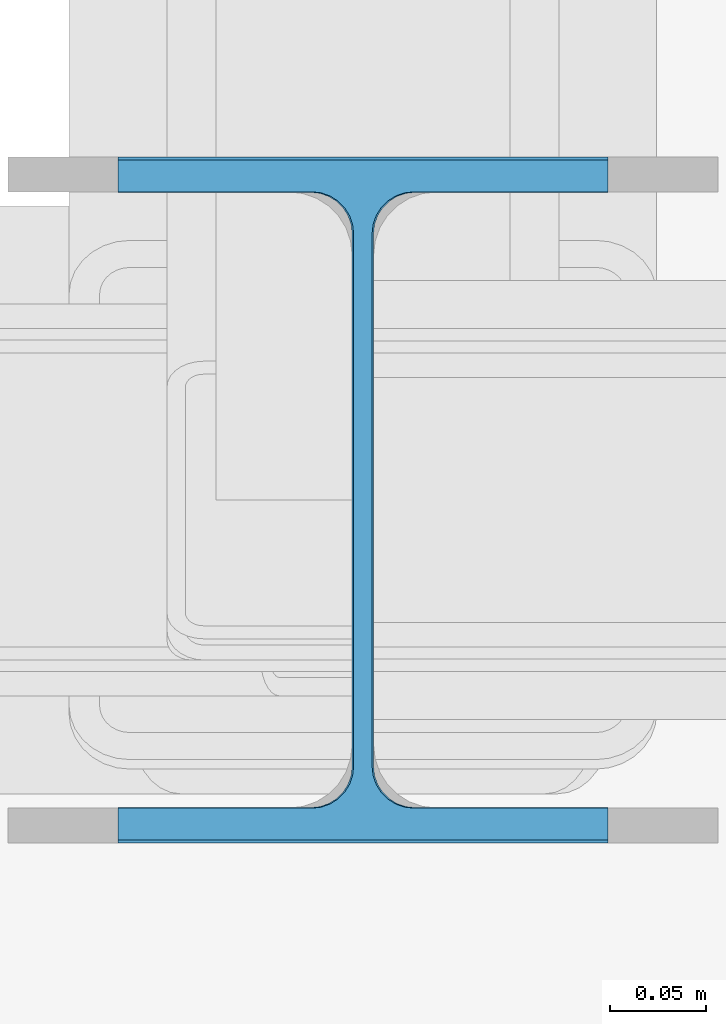
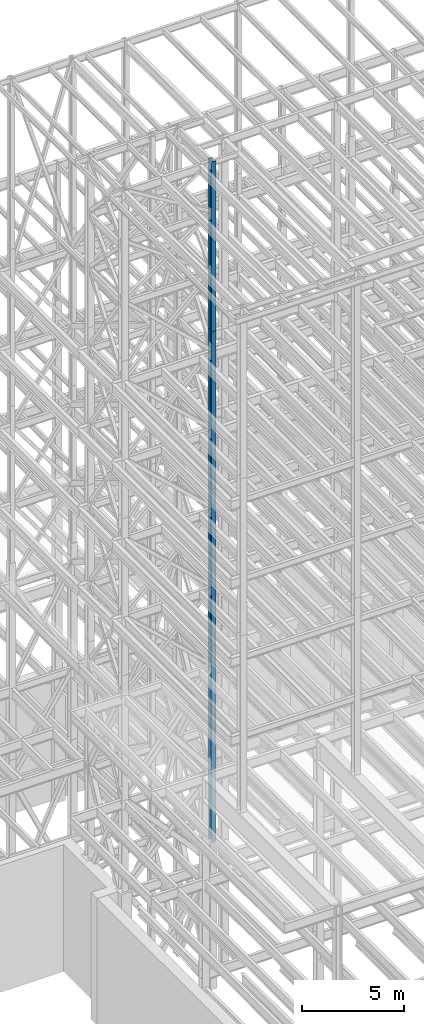
# One storey, part 11 of 150: 4 columns.
"""IFC2X3 building model written with IfcOpenShell, lengths in millimetres."""

from ifc_helpers import new_model, si_unit, frame, origin_with_axes, origin_2d_with_axis, place, context, subcontext, project, spatial, i_section, extrude, material, type_object, element, save


model = new_model("IFC2X3")

# Units and contexts
model_context = context("Model", 3, precision=1e-05, world=origin_with_axes())
body_context = subcontext(model_context, "Body", "Model", "MODEL_VIEW")
ifc_project = project(units=[si_unit("LENGTHUNIT", "METRE", prefix="MILLI"), si_unit("AREAUNIT", "SQUARE_METRE"), si_unit("VOLUMEUNIT", "CUBIC_METRE"), si_unit("MASSUNIT", "GRAM", prefix="KILO"), si_unit("TIMEUNIT", "SECOND"), si_unit("PLANEANGLEUNIT", "RADIAN"), si_unit("SOLIDANGLEUNIT", "STERADIAN"), si_unit("THERMODYNAMICTEMPERATUREUNIT", "DEGREE_CELSIUS"), si_unit("LUMINOUSINTENSITYUNIT", "LUMEN")], contexts=[model_context])

# Site, building, storey
site_placement = place(None, origin_with_axes())
site = spatial("IfcSite", under=ifc_project, at=site_placement, CompositionType="ELEMENT")
building_placement = place(site_placement, origin_with_axes())
building = spatial("IfcBuilding", under=site, at=building_placement, Name="Undefined", CompositionType="ELEMENT")
storey_placement = place(building_placement, origin_with_axes())
storey = spatial("IfcBuildingStorey", under=building, at=storey_placement, Name="Undefined", CompositionType="ELEMENT", Elevation=0.0)

# Columns
ifc_material = material(Name="STEEL/A992")
column_type_1 = type_object("IfcColumnType", Name="W14X61", PredefinedType="NOTDEFINED")
column_1_placement = place(storey_placement, frame((10312.39949708, 21043.9, 55702.2), z_axis=(0.0, 0.0, 1.0), x_axis=(1.0, 0.0, 0.0)))
element("IfcColumn", 1, at=column_1_placement, inside=storey, type_object=column_type_1, material=ifc_material, Name="COLUMN", ObjectType="W14X61", context=body_context, shape_type="SweptSolid", body=[
    extrude(i_section(OverallWidth=254.0, OverallDepth=352.425, WebThickness=9.5249, FlangeThickness=16.383, FilletRadius=21.717, at=origin_2d_with_axis()), frame((0.0, 0.0, 10210.8), z_axis=(0.0, 0.0, -1.0), x_axis=(-1.0, 0.0, 0.0)), (0.0, 0.0, 1.0), 10210.8),
])
for number, where, z_axis, x_axis, name in (
    (2, (10312.39949708, 21043.9, 46253.4), (0.0, 0.0, 1.0), (1.0, 0.0, 0.0), "COLUMN"),
    (3, (10312.39949708, 21043.9, 36804.6), (0.0, 0.0, 1.0), (1.0, 0.0, 0.0), "COLUMN"),
):
    element("IfcColumn", number, at=place(storey_placement, frame(where, z_axis=z_axis, x_axis=x_axis)), inside=storey, type_object=column_type_1, material=ifc_material, Name=name, ObjectType="W14X61", context=body_context, shape_type="SweptSolid", body=[
        extrude(i_section(OverallWidth=254.0, OverallDepth=352.425, WebThickness=9.5249, FlangeThickness=16.383, FilletRadius=21.717, at=origin_2d_with_axis()), frame((0.0, 0.0, 9448.8), z_axis=(0.0, 0.0, -1.0), x_axis=(-1.0, 0.0, 0.0)), (0.0, 0.0, 1.0), 9448.8),
    ])
column_type_2 = type_object("IfcColumnType", Name="W14X68", PredefinedType="NOTDEFINED")
column_2_placement = place(storey_placement, frame((10312.39949708, 21043.9, 24993.6), z_axis=(0.0, 0.0, 1.0), x_axis=(1.0, 0.0, 0.0)))
element("IfcColumn", 4, at=column_2_placement, inside=storey, type_object=column_type_2, material=ifc_material, Name="COLUMN", ObjectType="W14X68", context=body_context, shape_type="SweptSolid", body=[
    extrude(i_section(OverallWidth=254.0, OverallDepth=355.6, WebThickness=11.1125, FlangeThickness=18.288, FilletRadius=21.3994, at=origin_2d_with_axis()), frame((0.0, 0.0, 11811.0), z_axis=(0.0, 0.0, -1.0), x_axis=(-1.0, 0.0, 0.0)), (0.0, 0.0, 1.0), 11811.0),
])

save(model, "model.ifc")
